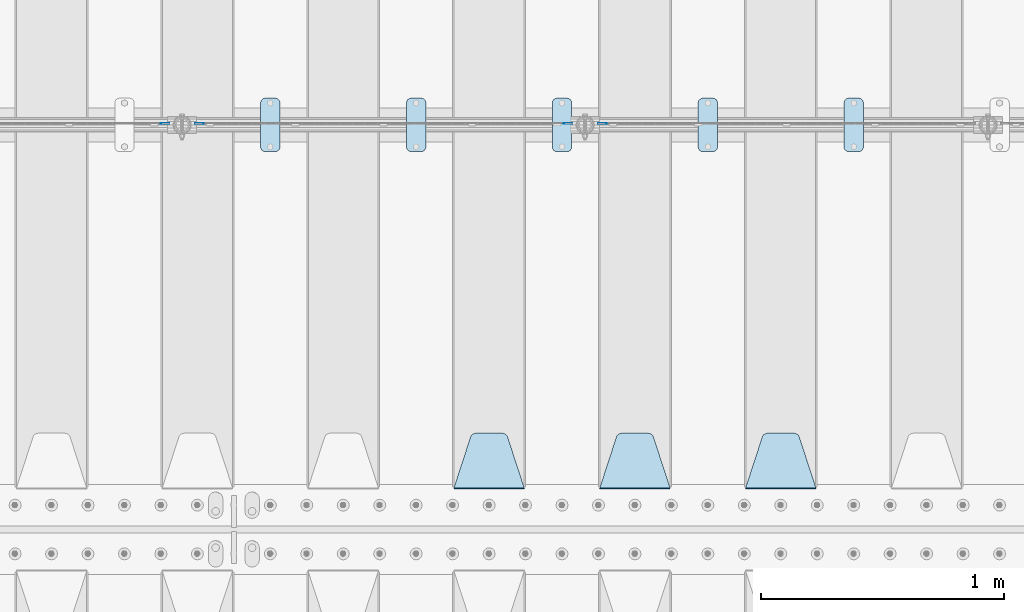
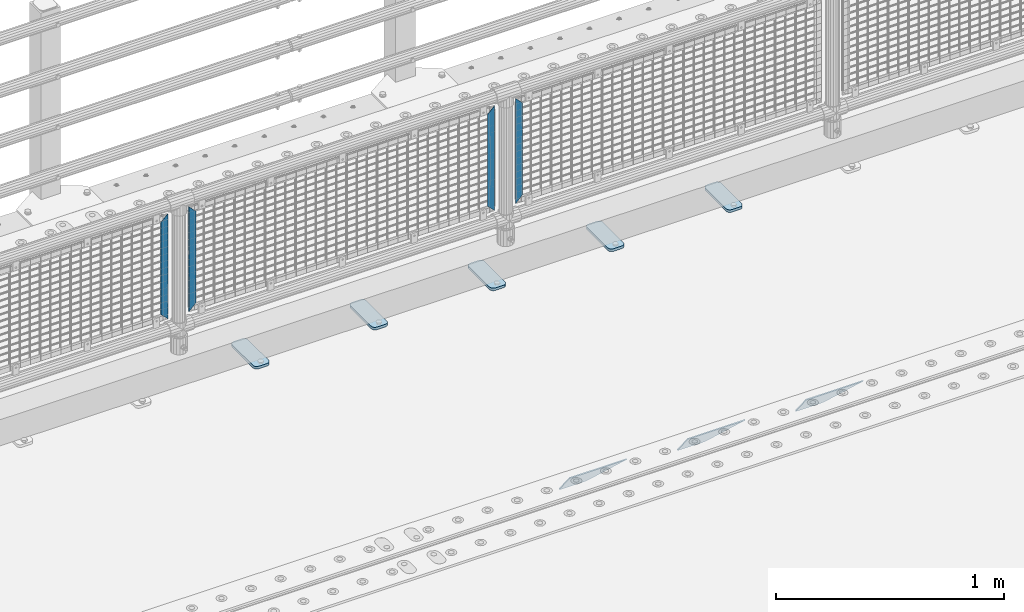
# One storey, part 213 of 240: 12 plates.
"""IFC2X3 building model written with IfcOpenShell, lengths in millimetres."""

from ifc_helpers import new_model, si_unit, frame, origin_with_axes, place, context, subcontext, project, spatial, faceted_brep, material, type_object, element, save


model = new_model("IFC2X3")

# Units and contexts
model_context = context("Model", 3, precision=1e-05, world=origin_with_axes())
body_context = subcontext(model_context, "Body", "Model", "MODEL_VIEW")
ifc_project = project(units=[si_unit("LENGTHUNIT", "METRE", prefix="MILLI"), si_unit("AREAUNIT", "SQUARE_METRE"), si_unit("VOLUMEUNIT", "CUBIC_METRE"), si_unit("MASSUNIT", "GRAM", prefix="KILO"), si_unit("TIMEUNIT", "SECOND"), si_unit("PLANEANGLEUNIT", "RADIAN"), si_unit("SOLIDANGLEUNIT", "STERADIAN"), si_unit("THERMODYNAMICTEMPERATUREUNIT", "DEGREE_CELSIUS"), si_unit("LUMINOUSINTENSITYUNIT", "LUMEN")], contexts=[model_context])

# Site, building, storey
site_placement = place(None, origin_with_axes())
site = spatial("IfcSite", under=ifc_project, at=site_placement, CompositionType="ELEMENT")
building_placement = place(site_placement, origin_with_axes())
building = spatial("IfcBuilding", under=site, at=building_placement, Name="Standard", CompositionType="ELEMENT")
storey_placement = place(building_placement, origin_with_axes())
storey = spatial("IfcBuildingStorey", under=building, at=storey_placement, Name="Undefined", CompositionType="ELEMENT", Elevation=0.0)

# Plates
ifc_material_1 = material(Name="STEEL/S355N")
plate_type_1 = type_object("IfcPlateType", PredefinedType="NOTDEFINED")
plate_1_placement = place(storey_placement, frame((48995.0, 33168.232233047, -1.76776695296758), z_axis=(0.0, 0.707106781186547, -0.707106781186548), x_axis=(-1.0, 0.0, 0.0)))
element("IfcPlate", 1, at=plate_1_placement, inside=storey, type_object=plate_type_1, material=ifc_material_1, context=body_context, shape_type="Brep", body=[
    faceted_brep([(0.0, -2.5, 0.0), (69.345504679477, -2.50000000000364, 300.171731424827), (69.345504679477, 2.49999999999636, 300.171731424827), (0.0, 2.5, 0.0), (70.927406119954, -2.50000000000364, 304.897442415397), (70.927406119954, 2.49999999999636, 304.897442415397), (73.3818627772271, -2.50000000000728, 309.234538108525), (73.3818627772271, 2.49999999999636, 309.234538108529), (76.6187032999587, -2.50000000000728, 313.023683126099), (76.6187032999587, 2.49999999999636, 313.023683126103), (80.5190132705029, -2.50000000000364, 316.125672595368), (80.5190132705029, 2.49999999999636, 316.125672595368), (84.9395038596849, -2.50000000000364, 318.426546230472), (84.9395038596849, 2.49999999999636, 318.426546230472), (89.7177759439219, -2.5, 319.841774983277), (89.7177759439219, 2.49999999999636, 319.841774983273), (94.6782862926484, -2.50000000000364, 320.319366455074), (94.6782862926484, 2.49999999999636, 320.319366455074), (195.321713707352, -2.50000000000364, 320.319366455074), (195.321713707352, 2.49999999999636, 320.319366455074), (200.282224056078, -2.50000000000364, 319.841774983273), (200.282224056078, 2.49999999999636, 319.841774983273), (205.060496140315, -2.50000000000364, 318.426546230472), (205.060496140315, 2.49999999999636, 318.426546230472), (209.480986729497, -2.50000000000364, 316.125672595368), (209.480986729497, 2.49999999999636, 316.125672595368), (213.381296700041, -2.50000000000728, 313.023683126099), (213.381296700041, 2.49999999999272, 313.023683126099), (216.618137222766, -2.50000000000364, 309.234538108522), (216.618137222766, 2.49999999999636, 309.234538108522), (219.072593880039, -2.50000000000364, 304.897442415397), (219.072593880039, 2.49999999999636, 304.897442415397), (220.654495320523, -2.50000000000364, 300.171731424827), (220.654495320523, 2.49999999999636, 300.171731424827), (290.0, -2.50000000000364, -3.63797880709171e-12), (290.0, 2.49999999999636, -3.63797880709171e-12)], [[[0, 1, 2, 3]], [[1, 4, 5, 2]], [[4, 6, 7, 5]], [[6, 8, 9, 7]], [[8, 10, 11, 9]], [[10, 12, 13, 11]], [[12, 14, 15, 13]], [[14, 16, 17, 15]], [[16, 18, 19, 17]], [[18, 20, 21, 19]], [[20, 22, 23, 21]], [[22, 24, 25, 23]], [[24, 26, 27, 25]], [[26, 28, 29, 27]], [[28, 30, 31, 29]], [[30, 32, 33, 31]], [[32, 34, 35, 33]], [[34, 0, 3, 35]], [[5, 7, 9, 11, 13, 15, 17, 19, 21, 23, 25, 27, 29, 31, 33, 35, 3, 2]], [[34, 32, 30, 28, 26, 24, 22, 20, 18, 16, 14, 12, 10, 8, 6, 4, 1, 0]]]),
])
plate_2_placement = place(storey_placement, frame((48395.0, 33168.232233047, -1.76776695296758), z_axis=(0.0, 0.707106781186547, -0.707106781186548), x_axis=(-1.0, 0.0, 0.0)))
element("IfcPlate", 2, at=plate_2_placement, inside=storey, type_object=plate_type_1, material=ifc_material_1, context=body_context, shape_type="Brep", body=[
    faceted_brep([(0.0, -2.5, 0.0), (69.345504679477, -2.50000000000364, 300.171731424827), (69.345504679477, 2.49999999999636, 300.171731424827), (0.0, 2.5, 0.0), (70.927406119954, -2.50000000000364, 304.897442415397), (70.927406119954, 2.49999999999636, 304.897442415397), (73.3818627772271, -2.50000000000728, 309.234538108525), (73.3818627772271, 2.49999999999636, 309.234538108529), (76.6187032999587, -2.50000000000728, 313.023683126099), (76.6187032999587, 2.49999999999636, 313.023683126103), (80.5190132705029, -2.50000000000364, 316.125672595368), (80.5190132705029, 2.49999999999636, 316.125672595368), (84.9395038596849, -2.50000000000364, 318.426546230472), (84.9395038596849, 2.49999999999636, 318.426546230472), (89.7177759439219, -2.5, 319.841774983277), (89.7177759439219, 2.49999999999636, 319.841774983273), (94.6782862926484, -2.50000000000364, 320.319366455074), (94.6782862926484, 2.49999999999636, 320.319366455074), (195.321713707352, -2.50000000000364, 320.319366455074), (195.321713707352, 2.49999999999636, 320.319366455074), (200.282224056078, -2.50000000000364, 319.841774983273), (200.282224056078, 2.49999999999636, 319.841774983273), (205.060496140315, -2.50000000000364, 318.426546230472), (205.060496140315, 2.49999999999636, 318.426546230472), (209.480986729497, -2.50000000000364, 316.125672595368), (209.480986729497, 2.49999999999636, 316.125672595368), (213.381296700041, -2.50000000000728, 313.023683126099), (213.381296700041, 2.49999999999272, 313.023683126099), (216.618137222766, -2.50000000000364, 309.234538108522), (216.618137222766, 2.49999999999636, 309.234538108522), (219.072593880039, -2.50000000000364, 304.897442415397), (219.072593880039, 2.49999999999636, 304.897442415397), (220.654495320523, -2.50000000000364, 300.171731424827), (220.654495320523, 2.49999999999636, 300.171731424827), (290.0, -2.50000000000364, -3.63797880709171e-12), (290.0, 2.49999999999636, -3.63797880709171e-12)], [[[0, 1, 2, 3]], [[1, 4, 5, 2]], [[4, 6, 7, 5]], [[6, 8, 9, 7]], [[8, 10, 11, 9]], [[10, 12, 13, 11]], [[12, 14, 15, 13]], [[14, 16, 17, 15]], [[16, 18, 19, 17]], [[18, 20, 21, 19]], [[20, 22, 23, 21]], [[22, 24, 25, 23]], [[24, 26, 27, 25]], [[26, 28, 29, 27]], [[28, 30, 31, 29]], [[30, 32, 33, 31]], [[32, 34, 35, 33]], [[34, 0, 3, 35]], [[5, 7, 9, 11, 13, 15, 17, 19, 21, 23, 25, 27, 29, 31, 33, 35, 3, 2]], [[34, 32, 30, 28, 26, 24, 22, 20, 18, 16, 14, 12, 10, 8, 6, 4, 1, 0]]]),
])
plate_3_placement = place(storey_placement, frame((47795.0, 33168.232233047, -1.76776695296758), z_axis=(0.0, 0.707106781186547, -0.707106781186548), x_axis=(-1.0, 0.0, 0.0)))
element("IfcPlate", 3, at=plate_3_placement, inside=storey, type_object=plate_type_1, material=ifc_material_1, context=body_context, shape_type="Brep", body=[
    faceted_brep([(0.0, -2.5, 0.0), (69.345504679477, -2.50000000000364, 300.171731424827), (69.345504679477, 2.49999999999636, 300.171731424827), (0.0, 2.5, 0.0), (70.927406119954, -2.50000000000364, 304.897442415397), (70.927406119954, 2.49999999999636, 304.897442415397), (73.3818627772271, -2.50000000000728, 309.234538108525), (73.3818627772271, 2.49999999999636, 309.234538108529), (76.6187032999587, -2.50000000000728, 313.023683126099), (76.6187032999587, 2.49999999999636, 313.023683126103), (80.5190132705029, -2.50000000000364, 316.125672595368), (80.5190132705029, 2.49999999999636, 316.125672595368), (84.9395038596849, -2.50000000000364, 318.426546230472), (84.9395038596849, 2.49999999999636, 318.426546230472), (89.7177759439219, -2.5, 319.841774983277), (89.7177759439219, 2.49999999999636, 319.841774983273), (94.6782862926484, -2.50000000000364, 320.319366455074), (94.6782862926484, 2.49999999999636, 320.319366455074), (195.321713707352, -2.50000000000364, 320.319366455074), (195.321713707352, 2.49999999999636, 320.319366455074), (200.282224056078, -2.50000000000364, 319.841774983273), (200.282224056078, 2.49999999999636, 319.841774983273), (205.060496140315, -2.50000000000364, 318.426546230472), (205.060496140315, 2.49999999999636, 318.426546230472), (209.480986729497, -2.50000000000364, 316.125672595368), (209.480986729497, 2.49999999999636, 316.125672595368), (213.381296700041, -2.50000000000728, 313.023683126099), (213.381296700041, 2.49999999999272, 313.023683126099), (216.618137222766, -2.50000000000364, 309.234538108522), (216.618137222766, 2.49999999999636, 309.234538108522), (219.072593880039, -2.50000000000364, 304.897442415397), (219.072593880039, 2.49999999999636, 304.897442415397), (220.654495320523, -2.50000000000364, 300.171731424827), (220.654495320523, 2.49999999999636, 300.171731424827), (290.0, -2.50000000000364, -3.63797880709171e-12), (290.0, 2.49999999999636, -3.63797880709171e-12)], [[[0, 1, 2, 3]], [[1, 4, 5, 2]], [[4, 6, 7, 5]], [[6, 8, 9, 7]], [[8, 10, 11, 9]], [[10, 12, 13, 11]], [[12, 14, 15, 13]], [[14, 16, 17, 15]], [[16, 18, 19, 17]], [[18, 20, 21, 19]], [[20, 22, 23, 21]], [[22, 24, 25, 23]], [[24, 26, 27, 25]], [[26, 28, 29, 27]], [[28, 30, 31, 29]], [[30, 32, 33, 31]], [[32, 34, 35, 33]], [[34, 0, 3, 35]], [[5, 7, 9, 11, 13, 15, 17, 19, 21, 23, 25, 27, 29, 31, 33, 35, 3, 2]], [[34, 32, 30, 28, 26, 24, 22, 20, 18, 16, 14, 12, 10, 8, 6, 4, 1, 0]]]),
])
ifc_material_2 = material(Name="STEEL/S355J2")
plate_type_2 = type_object("IfcPlateType", PredefinedType="NOTDEFINED")
plate_4_placement = place(storey_placement, frame((49110.0, 34774.5, 21.0199999999977), z_axis=(1.0, 0.0, 0.0), x_axis=(0.0, -1.0, 0.0)))
element("IfcPlate", 4, at=plate_4_placement, inside=storey, type_object=plate_type_2, material=ifc_material_2, context=body_context, shape_type="Brep", body=[
    faceted_brep([(0.0, -7.0, 20.0), (0.0, -7.0, 60.0), (0.0, 7.0, 60.0), (0.0, 7.0, 20.0), (0.384294391937146, -7.0, 63.9018064403208), (0.384294391937146, 7.0, 63.9018064403208), (1.52240934977453, -7.0, 67.6536686473046), (1.52240934977453, 7.0, 67.6536686473046), (3.37060775394639, -7.0, 71.1114046603907), (3.37060775394639, 7.0, 71.1114046603907), (5.85786437626666, -7.0, 74.1421356237333), (5.85786437626666, 7.0, 74.1421356237333), (8.88859533960931, -7.0, 76.6293922460536), (8.88859533960931, 7.0, 76.6293922460536), (12.3463313526954, -7.0, 78.4775906502255), (12.3463313526954, 7.0, 78.4775906502255), (16.0981935596792, -7.0, 79.6157056080629), (16.0981935596792, 7.0, 79.6157056080629), (20.0, -7.0, 80.0), (20.0, 7.0, 80.0), (200.0, -7.0, 80.0), (200.0, 7.0, 80.0), (203.901806440321, -7.0, 79.6157056080629), (203.901806440321, 7.0, 79.6157056080629), (207.653668647305, -7.0, 78.4775906502255), (207.653668647305, 7.0, 78.4775906502255), (211.111404660391, -7.0, 76.6293922460536), (211.111404660391, 7.0, 76.6293922460536), (214.142135623733, -7.0, 74.1421356237333), (214.142135623733, 7.0, 74.1421356237333), (216.629392246054, -7.0, 71.1114046603907), (216.629392246054, 7.0, 71.1114046603907), (218.477590650225, -7.0, 67.6536686473046), (218.477590650225, 7.0, 67.6536686473046), (219.615705608063, -7.0, 63.9018064403208), (219.615705608063, 7.0, 63.9018064403208), (220.0, -7.0, 60.0), (220.0, 7.0, 60.0), (220.0, -7.0, 20.0), (220.0, 7.0, 20.0), (219.615705608063, -7.0, 16.0981935596792), (219.615705608063, 7.0, 16.0981935596792), (218.477590650225, -7.0, 12.3463313526954), (218.477590650225, 7.0, 12.3463313526954), (216.629392246054, -7.0, 8.88859533960931), (216.629392246054, 7.0, 8.88859533960931), (214.142135623733, -7.0, 5.85786437626666), (214.142135623733, 7.0, 5.85786437626666), (211.111404660391, -7.0, 3.37060775394639), (211.111404660391, 7.0, 3.37060775394639), (207.653668647305, -7.0, 1.52240934977453), (207.653668647305, 7.0, 1.52240934977453), (203.901806440321, -7.0, 0.384294391937146), (203.901806440321, 7.0, 0.384294391937146), (200.0, -7.0, 0.0), (200.0, 7.0, 0.0), (20.0, -7.0, 0.0), (20.0, 7.0, 0.0), (16.0981935596792, -7.0, 0.384294391937146), (16.0981935596792, 7.0, 0.384294391937146), (12.3463313526954, -7.0, 1.52240934977453), (12.3463313526954, 7.0, 1.52240934977453), (8.88859533960931, -7.0, 3.37060775394639), (8.88859533960931, 7.0, 3.37060775394639), (5.85786437626666, -7.0, 5.85786437626666), (5.85786437626666, 7.0, 5.85786437626666), (3.37060775394639, -7.0, 8.88859533960931), (3.37060775394639, 7.0, 8.88859533960931), (1.52240934977453, -7.0, 12.3463313526954), (1.52240934977453, 7.0, 12.3463313526954), (0.384294391937146, -7.0, 16.0981935596792), (0.384294391937146, 7.0, 16.0981935596792)], [[[0, 1, 2, 3]], [[1, 4, 5, 2]], [[4, 6, 7, 5]], [[6, 8, 9, 7]], [[8, 10, 11, 9]], [[10, 12, 13, 11]], [[12, 14, 15, 13]], [[14, 16, 17, 15]], [[16, 18, 19, 17]], [[18, 20, 21, 19]], [[20, 22, 23, 21]], [[22, 24, 25, 23]], [[24, 26, 27, 25]], [[26, 28, 29, 27]], [[28, 30, 31, 29]], [[30, 32, 33, 31]], [[32, 34, 35, 33]], [[34, 36, 37, 35]], [[36, 38, 39, 37]], [[38, 40, 41, 39]], [[40, 42, 43, 41]], [[42, 44, 45, 43]], [[44, 46, 47, 45]], [[46, 48, 49, 47]], [[48, 50, 51, 49]], [[50, 52, 53, 51]], [[52, 54, 55, 53]], [[54, 56, 57, 55]], [[56, 58, 59, 57]], [[58, 60, 61, 59]], [[60, 62, 63, 61]], [[62, 64, 65, 63]], [[64, 66, 67, 65]], [[66, 68, 69, 67]], [[68, 70, 71, 69]], [[70, 0, 3, 71]], [[5, 7, 9, 11, 13, 15, 17, 19, 21, 23, 25, 27, 29, 31, 33, 35, 37, 39, 41, 43, 45, 47, 49, 51, 53, 55, 57, 59, 61, 63, 65, 67, 69, 71, 3, 2]], [[70, 68, 66, 64, 62, 60, 58, 56, 54, 52, 50, 48, 46, 44, 42, 40, 38, 36, 34, 32, 30, 28, 26, 24, 22, 20, 18, 16, 14, 12, 10, 8, 6, 4, 1, 0]]]),
])
plate_5_placement = place(storey_placement, frame((48510.0, 34774.5, 21.0199999999977), z_axis=(1.0, 0.0, 0.0), x_axis=(0.0, -1.0, 0.0)))
element("IfcPlate", 5, at=plate_5_placement, inside=storey, type_object=plate_type_2, material=ifc_material_2, context=body_context, shape_type="Brep", body=[
    faceted_brep([(0.0, -7.0, 20.0), (0.0, -7.0, 60.0), (0.0, 7.0, 60.0), (0.0, 7.0, 20.0), (0.384294391937146, -7.0, 63.9018064403208), (0.384294391937146, 7.0, 63.9018064403208), (1.52240934977453, -7.0, 67.6536686473046), (1.52240934977453, 7.0, 67.6536686473046), (3.37060775394639, -7.0, 71.1114046603907), (3.37060775394639, 7.0, 71.1114046603907), (5.85786437626666, -7.0, 74.1421356237333), (5.85786437626666, 7.0, 74.1421356237333), (8.88859533960931, -7.0, 76.6293922460536), (8.88859533960931, 7.0, 76.6293922460536), (12.3463313526954, -7.0, 78.4775906502255), (12.3463313526954, 7.0, 78.4775906502255), (16.0981935596792, -7.0, 79.6157056080629), (16.0981935596792, 7.0, 79.6157056080629), (20.0, -7.0, 80.0), (20.0, 7.0, 80.0), (200.0, -7.0, 80.0), (200.0, 7.0, 80.0), (203.901806440321, -7.0, 79.6157056080629), (203.901806440321, 7.0, 79.6157056080629), (207.653668647305, -7.0, 78.4775906502255), (207.653668647305, 7.0, 78.4775906502255), (211.111404660391, -7.0, 76.6293922460536), (211.111404660391, 7.0, 76.6293922460536), (214.142135623733, -7.0, 74.1421356237333), (214.142135623733, 7.0, 74.1421356237333), (216.629392246054, -7.0, 71.1114046603907), (216.629392246054, 7.0, 71.1114046603907), (218.477590650225, -7.0, 67.6536686473046), (218.477590650225, 7.0, 67.6536686473046), (219.615705608063, -7.0, 63.9018064403208), (219.615705608063, 7.0, 63.9018064403208), (220.0, -7.0, 60.0), (220.0, 7.0, 60.0), (220.0, -7.0, 20.0), (220.0, 7.0, 20.0), (219.615705608063, -7.0, 16.0981935596792), (219.615705608063, 7.0, 16.0981935596792), (218.477590650225, -7.0, 12.3463313526954), (218.477590650225, 7.0, 12.3463313526954), (216.629392246054, -7.0, 8.88859533960931), (216.629392246054, 7.0, 8.88859533960931), (214.142135623733, -7.0, 5.85786437626666), (214.142135623733, 7.0, 5.85786437626666), (211.111404660391, -7.0, 3.37060775394639), (211.111404660391, 7.0, 3.37060775394639), (207.653668647305, -7.0, 1.52240934977453), (207.653668647305, 7.0, 1.52240934977453), (203.901806440321, -7.0, 0.384294391937146), (203.901806440321, 7.0, 0.384294391937146), (200.0, -7.0, 0.0), (200.0, 7.0, 0.0), (20.0, -7.0, 0.0), (20.0, 7.0, 0.0), (16.0981935596792, -7.0, 0.384294391937146), (16.0981935596792, 7.0, 0.384294391937146), (12.3463313526954, -7.0, 1.52240934977453), (12.3463313526954, 7.0, 1.52240934977453), (8.88859533960931, -7.0, 3.37060775394639), (8.88859533960931, 7.0, 3.37060775394639), (5.85786437626666, -7.0, 5.85786437626666), (5.85786437626666, 7.0, 5.85786437626666), (3.37060775394639, -7.0, 8.88859533960931), (3.37060775394639, 7.0, 8.88859533960931), (1.52240934977453, -7.0, 12.3463313526954), (1.52240934977453, 7.0, 12.3463313526954), (0.384294391937146, -7.0, 16.0981935596792), (0.384294391937146, 7.0, 16.0981935596792)], [[[0, 1, 2, 3]], [[1, 4, 5, 2]], [[4, 6, 7, 5]], [[6, 8, 9, 7]], [[8, 10, 11, 9]], [[10, 12, 13, 11]], [[12, 14, 15, 13]], [[14, 16, 17, 15]], [[16, 18, 19, 17]], [[18, 20, 21, 19]], [[20, 22, 23, 21]], [[22, 24, 25, 23]], [[24, 26, 27, 25]], [[26, 28, 29, 27]], [[28, 30, 31, 29]], [[30, 32, 33, 31]], [[32, 34, 35, 33]], [[34, 36, 37, 35]], [[36, 38, 39, 37]], [[38, 40, 41, 39]], [[40, 42, 43, 41]], [[42, 44, 45, 43]], [[44, 46, 47, 45]], [[46, 48, 49, 47]], [[48, 50, 51, 49]], [[50, 52, 53, 51]], [[52, 54, 55, 53]], [[54, 56, 57, 55]], [[56, 58, 59, 57]], [[58, 60, 61, 59]], [[60, 62, 63, 61]], [[62, 64, 65, 63]], [[64, 66, 67, 65]], [[66, 68, 69, 67]], [[68, 70, 71, 69]], [[70, 0, 3, 71]], [[5, 7, 9, 11, 13, 15, 17, 19, 21, 23, 25, 27, 29, 31, 33, 35, 37, 39, 41, 43, 45, 47, 49, 51, 53, 55, 57, 59, 61, 63, 65, 67, 69, 71, 3, 2]], [[70, 68, 66, 64, 62, 60, 58, 56, 54, 52, 50, 48, 46, 44, 42, 40, 38, 36, 34, 32, 30, 28, 26, 24, 22, 20, 18, 16, 14, 12, 10, 8, 6, 4, 1, 0]]]),
])
plate_6_placement = place(storey_placement, frame((47910.0, 34774.5, 21.0199999999977), z_axis=(1.0, 0.0, 0.0), x_axis=(0.0, -1.0, 0.0)))
element("IfcPlate", 6, at=plate_6_placement, inside=storey, type_object=plate_type_2, material=ifc_material_2, context=body_context, shape_type="Brep", body=[
    faceted_brep([(0.0, -7.0, 20.0), (0.0, -7.0, 60.0), (0.0, 7.0, 60.0), (0.0, 7.0, 20.0), (0.384294391937146, -7.0, 63.9018064403208), (0.384294391937146, 7.0, 63.9018064403208), (1.52240934977453, -7.0, 67.6536686473046), (1.52240934977453, 7.0, 67.6536686473046), (3.37060775394639, -7.0, 71.1114046603907), (3.37060775394639, 7.0, 71.1114046603907), (5.85786437626666, -7.0, 74.1421356237333), (5.85786437626666, 7.0, 74.1421356237333), (8.88859533960931, -7.0, 76.6293922460536), (8.88859533960931, 7.0, 76.6293922460536), (12.3463313526954, -7.0, 78.4775906502255), (12.3463313526954, 7.0, 78.4775906502255), (16.0981935596792, -7.0, 79.6157056080629), (16.0981935596792, 7.0, 79.6157056080629), (20.0, -7.0, 80.0), (20.0, 7.0, 80.0), (200.0, -7.0, 80.0), (200.0, 7.0, 80.0), (203.901806440321, -7.0, 79.6157056080629), (203.901806440321, 7.0, 79.6157056080629), (207.653668647305, -7.0, 78.4775906502255), (207.653668647305, 7.0, 78.4775906502255), (211.111404660391, -7.0, 76.6293922460536), (211.111404660391, 7.0, 76.6293922460536), (214.142135623733, -7.0, 74.1421356237333), (214.142135623733, 7.0, 74.1421356237333), (216.629392246054, -7.0, 71.1114046603907), (216.629392246054, 7.0, 71.1114046603907), (218.477590650225, -7.0, 67.6536686473046), (218.477590650225, 7.0, 67.6536686473046), (219.615705608063, -7.0, 63.9018064403208), (219.615705608063, 7.0, 63.9018064403208), (220.0, -7.0, 60.0), (220.0, 7.0, 60.0), (220.0, -7.0, 20.0), (220.0, 7.0, 20.0), (219.615705608063, -7.0, 16.0981935596792), (219.615705608063, 7.0, 16.0981935596792), (218.477590650225, -7.0, 12.3463313526954), (218.477590650225, 7.0, 12.3463313526954), (216.629392246054, -7.0, 8.88859533960931), (216.629392246054, 7.0, 8.88859533960931), (214.142135623733, -7.0, 5.85786437626666), (214.142135623733, 7.0, 5.85786437626666), (211.111404660391, -7.0, 3.37060775394639), (211.111404660391, 7.0, 3.37060775394639), (207.653668647305, -7.0, 1.52240934977453), (207.653668647305, 7.0, 1.52240934977453), (203.901806440321, -7.0, 0.384294391937146), (203.901806440321, 7.0, 0.384294391937146), (200.0, -7.0, 0.0), (200.0, 7.0, 0.0), (20.0, -7.0, 0.0), (20.0, 7.0, 0.0), (16.0981935596792, -7.0, 0.384294391937146), (16.0981935596792, 7.0, 0.384294391937146), (12.3463313526954, -7.0, 1.52240934977453), (12.3463313526954, 7.0, 1.52240934977453), (8.88859533960931, -7.0, 3.37060775394639), (8.88859533960931, 7.0, 3.37060775394639), (5.85786437626666, -7.0, 5.85786437626666), (5.85786437626666, 7.0, 5.85786437626666), (3.37060775394639, -7.0, 8.88859533960931), (3.37060775394639, 7.0, 8.88859533960931), (1.52240934977453, -7.0, 12.3463313526954), (1.52240934977453, 7.0, 12.3463313526954), (0.384294391937146, -7.0, 16.0981935596792), (0.384294391937146, 7.0, 16.0981935596792)], [[[0, 1, 2, 3]], [[1, 4, 5, 2]], [[4, 6, 7, 5]], [[6, 8, 9, 7]], [[8, 10, 11, 9]], [[10, 12, 13, 11]], [[12, 14, 15, 13]], [[14, 16, 17, 15]], [[16, 18, 19, 17]], [[18, 20, 21, 19]], [[20, 22, 23, 21]], [[22, 24, 25, 23]], [[24, 26, 27, 25]], [[26, 28, 29, 27]], [[28, 30, 31, 29]], [[30, 32, 33, 31]], [[32, 34, 35, 33]], [[34, 36, 37, 35]], [[36, 38, 39, 37]], [[38, 40, 41, 39]], [[40, 42, 43, 41]], [[42, 44, 45, 43]], [[44, 46, 47, 45]], [[46, 48, 49, 47]], [[48, 50, 51, 49]], [[50, 52, 53, 51]], [[52, 54, 55, 53]], [[54, 56, 57, 55]], [[56, 58, 59, 57]], [[58, 60, 61, 59]], [[60, 62, 63, 61]], [[62, 64, 65, 63]], [[64, 66, 67, 65]], [[66, 68, 69, 67]], [[68, 70, 71, 69]], [[70, 0, 3, 71]], [[5, 7, 9, 11, 13, 15, 17, 19, 21, 23, 25, 27, 29, 31, 33, 35, 37, 39, 41, 43, 45, 47, 49, 51, 53, 55, 57, 59, 61, 63, 65, 67, 69, 71, 3, 2]], [[70, 68, 66, 64, 62, 60, 58, 56, 54, 52, 50, 48, 46, 44, 42, 40, 38, 36, 34, 32, 30, 28, 26, 24, 22, 20, 18, 16, 14, 12, 10, 8, 6, 4, 1, 0]]]),
])
plate_7_placement = place(storey_placement, frame((47310.0, 34774.5, 21.0199999999977), z_axis=(1.0, 0.0, 0.0), x_axis=(0.0, -1.0, 0.0)))
element("IfcPlate", 7, at=plate_7_placement, inside=storey, type_object=plate_type_2, material=ifc_material_2, context=body_context, shape_type="Brep", body=[
    faceted_brep([(0.0, -7.0, 20.0), (0.0, -7.0, 60.0), (0.0, 7.0, 60.0), (0.0, 7.0, 20.0), (0.384294391937146, -7.0, 63.9018064403208), (0.384294391937146, 7.0, 63.9018064403208), (1.52240934977453, -7.0, 67.6536686473046), (1.52240934977453, 7.0, 67.6536686473046), (3.37060775394639, -7.0, 71.1114046603907), (3.37060775394639, 7.0, 71.1114046603907), (5.85786437626666, -7.0, 74.1421356237333), (5.85786437626666, 7.0, 74.1421356237333), (8.88859533960931, -7.0, 76.6293922460536), (8.88859533960931, 7.0, 76.6293922460536), (12.3463313526954, -7.0, 78.4775906502255), (12.3463313526954, 7.0, 78.4775906502255), (16.0981935596792, -7.0, 79.6157056080629), (16.0981935596792, 7.0, 79.6157056080629), (20.0, -7.0, 80.0), (20.0, 7.0, 80.0), (200.0, -7.0, 80.0), (200.0, 7.0, 80.0), (203.901806440321, -7.0, 79.6157056080629), (203.901806440321, 7.0, 79.6157056080629), (207.653668647305, -7.0, 78.4775906502255), (207.653668647305, 7.0, 78.4775906502255), (211.111404660391, -7.0, 76.6293922460536), (211.111404660391, 7.0, 76.6293922460536), (214.142135623733, -7.0, 74.1421356237333), (214.142135623733, 7.0, 74.1421356237333), (216.629392246054, -7.0, 71.1114046603907), (216.629392246054, 7.0, 71.1114046603907), (218.477590650225, -7.0, 67.6536686473046), (218.477590650225, 7.0, 67.6536686473046), (219.615705608063, -7.0, 63.9018064403208), (219.615705608063, 7.0, 63.9018064403208), (220.0, -7.0, 60.0), (220.0, 7.0, 60.0), (220.0, -7.0, 20.0), (220.0, 7.0, 20.0), (219.615705608063, -7.0, 16.0981935596792), (219.615705608063, 7.0, 16.0981935596792), (218.477590650225, -7.0, 12.3463313526954), (218.477590650225, 7.0, 12.3463313526954), (216.629392246054, -7.0, 8.88859533960931), (216.629392246054, 7.0, 8.88859533960931), (214.142135623733, -7.0, 5.85786437626666), (214.142135623733, 7.0, 5.85786437626666), (211.111404660391, -7.0, 3.37060775394639), (211.111404660391, 7.0, 3.37060775394639), (207.653668647305, -7.0, 1.52240934977453), (207.653668647305, 7.0, 1.52240934977453), (203.901806440321, -7.0, 0.384294391937146), (203.901806440321, 7.0, 0.384294391937146), (200.0, -7.0, 0.0), (200.0, 7.0, 0.0), (20.0, -7.0, 0.0), (20.0, 7.0, 0.0), (16.0981935596792, -7.0, 0.384294391937146), (16.0981935596792, 7.0, 0.384294391937146), (12.3463313526954, -7.0, 1.52240934977453), (12.3463313526954, 7.0, 1.52240934977453), (8.88859533960931, -7.0, 3.37060775394639), (8.88859533960931, 7.0, 3.37060775394639), (5.85786437626666, -7.0, 5.85786437626666), (5.85786437626666, 7.0, 5.85786437626666), (3.37060775394639, -7.0, 8.88859533960931), (3.37060775394639, 7.0, 8.88859533960931), (1.52240934977453, -7.0, 12.3463313526954), (1.52240934977453, 7.0, 12.3463313526954), (0.384294391937146, -7.0, 16.0981935596792), (0.384294391937146, 7.0, 16.0981935596792)], [[[0, 1, 2, 3]], [[1, 4, 5, 2]], [[4, 6, 7, 5]], [[6, 8, 9, 7]], [[8, 10, 11, 9]], [[10, 12, 13, 11]], [[12, 14, 15, 13]], [[14, 16, 17, 15]], [[16, 18, 19, 17]], [[18, 20, 21, 19]], [[20, 22, 23, 21]], [[22, 24, 25, 23]], [[24, 26, 27, 25]], [[26, 28, 29, 27]], [[28, 30, 31, 29]], [[30, 32, 33, 31]], [[32, 34, 35, 33]], [[34, 36, 37, 35]], [[36, 38, 39, 37]], [[38, 40, 41, 39]], [[40, 42, 43, 41]], [[42, 44, 45, 43]], [[44, 46, 47, 45]], [[46, 48, 49, 47]], [[48, 50, 51, 49]], [[50, 52, 53, 51]], [[52, 54, 55, 53]], [[54, 56, 57, 55]], [[56, 58, 59, 57]], [[58, 60, 61, 59]], [[60, 62, 63, 61]], [[62, 64, 65, 63]], [[64, 66, 67, 65]], [[66, 68, 69, 67]], [[68, 70, 71, 69]], [[70, 0, 3, 71]], [[5, 7, 9, 11, 13, 15, 17, 19, 21, 23, 25, 27, 29, 31, 33, 35, 37, 39, 41, 43, 45, 47, 49, 51, 53, 55, 57, 59, 61, 63, 65, 67, 69, 71, 3, 2]], [[70, 68, 66, 64, 62, 60, 58, 56, 54, 52, 50, 48, 46, 44, 42, 40, 38, 36, 34, 32, 30, 28, 26, 24, 22, 20, 18, 16, 14, 12, 10, 8, 6, 4, 1, 0]]]),
])
plate_8_placement = place(storey_placement, frame((46710.0, 34774.5, 21.0199999999977), z_axis=(1.0, 0.0, 0.0), x_axis=(0.0, -1.0, 0.0)))
element("IfcPlate", 8, at=plate_8_placement, inside=storey, type_object=plate_type_2, material=ifc_material_2, context=body_context, shape_type="Brep", body=[
    faceted_brep([(0.0, -7.0, 20.0), (0.0, -7.0, 60.0), (0.0, 7.0, 60.0), (0.0, 7.0, 20.0), (0.384294391937146, -7.0, 63.9018064403208), (0.384294391937146, 7.0, 63.9018064403208), (1.52240934977453, -7.0, 67.6536686473046), (1.52240934977453, 7.0, 67.6536686473046), (3.37060775394639, -7.0, 71.1114046603907), (3.37060775394639, 7.0, 71.1114046603907), (5.85786437626666, -7.0, 74.1421356237333), (5.85786437626666, 7.0, 74.1421356237333), (8.88859533960931, -7.0, 76.6293922460536), (8.88859533960931, 7.0, 76.6293922460536), (12.3463313526954, -7.0, 78.4775906502255), (12.3463313526954, 7.0, 78.4775906502255), (16.0981935596792, -7.0, 79.6157056080629), (16.0981935596792, 7.0, 79.6157056080629), (20.0, -7.0, 80.0), (20.0, 7.0, 80.0), (200.0, -7.0, 80.0), (200.0, 7.0, 80.0), (203.901806440321, -7.0, 79.6157056080629), (203.901806440321, 7.0, 79.6157056080629), (207.653668647305, -7.0, 78.4775906502255), (207.653668647305, 7.0, 78.4775906502255), (211.111404660391, -7.0, 76.6293922460536), (211.111404660391, 7.0, 76.6293922460536), (214.142135623733, -7.0, 74.1421356237333), (214.142135623733, 7.0, 74.1421356237333), (216.629392246054, -7.0, 71.1114046603907), (216.629392246054, 7.0, 71.1114046603907), (218.477590650225, -7.0, 67.6536686473046), (218.477590650225, 7.0, 67.6536686473046), (219.615705608063, -7.0, 63.9018064403208), (219.615705608063, 7.0, 63.9018064403208), (220.0, -7.0, 60.0), (220.0, 7.0, 60.0), (220.0, -7.0, 20.0), (220.0, 7.0, 20.0), (219.615705608063, -7.0, 16.0981935596792), (219.615705608063, 7.0, 16.0981935596792), (218.477590650225, -7.0, 12.3463313526954), (218.477590650225, 7.0, 12.3463313526954), (216.629392246054, -7.0, 8.88859533960931), (216.629392246054, 7.0, 8.88859533960931), (214.142135623733, -7.0, 5.85786437626666), (214.142135623733, 7.0, 5.85786437626666), (211.111404660391, -7.0, 3.37060775394639), (211.111404660391, 7.0, 3.37060775394639), (207.653668647305, -7.0, 1.52240934977453), (207.653668647305, 7.0, 1.52240934977453), (203.901806440321, -7.0, 0.384294391937146), (203.901806440321, 7.0, 0.384294391937146), (200.0, -7.0, 0.0), (200.0, 7.0, 0.0), (20.0, -7.0, 0.0), (20.0, 7.0, 0.0), (16.0981935596792, -7.0, 0.384294391937146), (16.0981935596792, 7.0, 0.384294391937146), (12.3463313526954, -7.0, 1.52240934977453), (12.3463313526954, 7.0, 1.52240934977453), (8.88859533960931, -7.0, 3.37060775394639), (8.88859533960931, 7.0, 3.37060775394639), (5.85786437626666, -7.0, 5.85786437626666), (5.85786437626666, 7.0, 5.85786437626666), (3.37060775394639, -7.0, 8.88859533960931), (3.37060775394639, 7.0, 8.88859533960931), (1.52240934977453, -7.0, 12.3463313526954), (1.52240934977453, 7.0, 12.3463313526954), (0.384294391937146, -7.0, 16.0981935596792), (0.384294391937146, 7.0, 16.0981935596792)], [[[0, 1, 2, 3]], [[1, 4, 5, 2]], [[4, 6, 7, 5]], [[6, 8, 9, 7]], [[8, 10, 11, 9]], [[10, 12, 13, 11]], [[12, 14, 15, 13]], [[14, 16, 17, 15]], [[16, 18, 19, 17]], [[18, 20, 21, 19]], [[20, 22, 23, 21]], [[22, 24, 25, 23]], [[24, 26, 27, 25]], [[26, 28, 29, 27]], [[28, 30, 31, 29]], [[30, 32, 33, 31]], [[32, 34, 35, 33]], [[34, 36, 37, 35]], [[36, 38, 39, 37]], [[38, 40, 41, 39]], [[40, 42, 43, 41]], [[42, 44, 45, 43]], [[44, 46, 47, 45]], [[46, 48, 49, 47]], [[48, 50, 51, 49]], [[50, 52, 53, 51]], [[52, 54, 55, 53]], [[54, 56, 57, 55]], [[56, 58, 59, 57]], [[58, 60, 61, 59]], [[60, 62, 63, 61]], [[62, 64, 65, 63]], [[64, 66, 67, 65]], [[66, 68, 69, 67]], [[68, 70, 71, 69]], [[70, 0, 3, 71]], [[5, 7, 9, 11, 13, 15, 17, 19, 21, 23, 25, 27, 29, 31, 33, 35, 37, 39, 41, 43, 45, 47, 49, 51, 53, 55, 57, 59, 61, 63, 65, 67, 69, 71, 3, 2]], [[70, 68, 66, 64, 62, 60, 58, 56, 54, 52, 50, 48, 46, 44, 42, 40, 38, 36, 34, 32, 30, 28, 26, 24, 22, 20, 18, 16, 14, 12, 10, 8, 6, 4, 1, 0]]]),
])
ifc_material_3 = material(Name="Misc_Undefined")
plate_type_3 = type_object("IfcPlateType", PredefinedType="NOTDEFINED")
for number, where, z_axis, x_axis in (
    (9, (48133.509713541, 34670.5, 879.519963133601), (-0.707008801899317, 0.0, -0.707204746899292), (-0.707204746899293, 0.0, 0.707008801899317)),
    (10, (46475.509713541, 34670.5, 879.519963133601), (-0.707008801899317, 0.0, -0.707204746899292), (-0.707204746899293, 0.0, 0.707008801899317)),
):
    element("IfcPlate", number, at=place(storey_placement, frame(where, z_axis=z_axis, x_axis=x_axis)), inside=storey, type_object=plate_type_3, material=ifc_material_3, context=body_context, shape_type="Brep", body=[
        faceted_brep([(-7.27595761418343e-12, -1.49999999999272, 0.0), (-348.552185058594, -1.5, 348.65502929686), (-348.552185058594, 1.5, 348.65502929686), (0.0, 1.50000000000728, 0.0), (-348.544891357415, -1.5, 398.152496337883), (-348.544891357415, 1.5, 398.152496337883), (49.5043945312573, -1.5, 6.54836185276508e-11), (49.5043945312573, 1.5, 6.54836185276508e-11)], [[[0, 1, 2, 3]], [[1, 4, 5, 2]], [[4, 6, 7, 5]], [[6, 0, 3, 7]], [[5, 7, 3, 2]], [[6, 4, 1, 0]]]),
    ])
for number, where, z_axis, x_axis in (
    (11, (47956.4996874836, 34670.5, 879.52), (0.707103624179501, 0.0, -0.707109938179499), (0.707109938179525, 0.0, 0.707103624179475)),
    (12, (46298.4996874836, 34670.5, 879.52), (0.707103624179501, 0.0, -0.707109938179499), (0.707109938179525, 0.0, 0.707103624179475)),
):
    element("IfcPlate", number, at=place(storey_placement, frame(where, z_axis=z_axis, x_axis=x_axis)), inside=storey, type_object=plate_type_3, material=ifc_material_3, context=body_context, shape_type="Brep", body=[
        faceted_brep([(-7.27595761418343e-12, -1.49999999999272, 0.0), (-348.605163574233, -1.5, 348.602081298821), (-348.605163574233, 1.5, 348.602081298821), (0.0, 1.50000000000728, 0.0), (-348.605163574226, -1.5, 398.099334716797), (-348.605163574226, 1.5, 398.099334716797), (49.4976959228443, -1.5, -1.09139364212751e-10), (49.4976959228443, 1.5, -1.09139364212751e-10)], [[[0, 1, 2, 3]], [[1, 4, 5, 2]], [[4, 6, 7, 5]], [[6, 0, 3, 7]], [[5, 7, 3, 2]], [[6, 4, 1, 0]]]),
    ])

save(model, "model.ifc")
